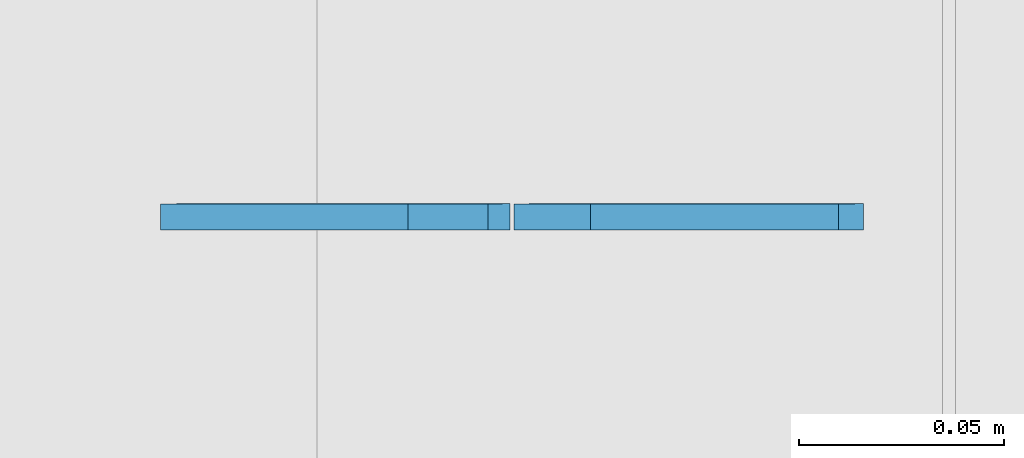
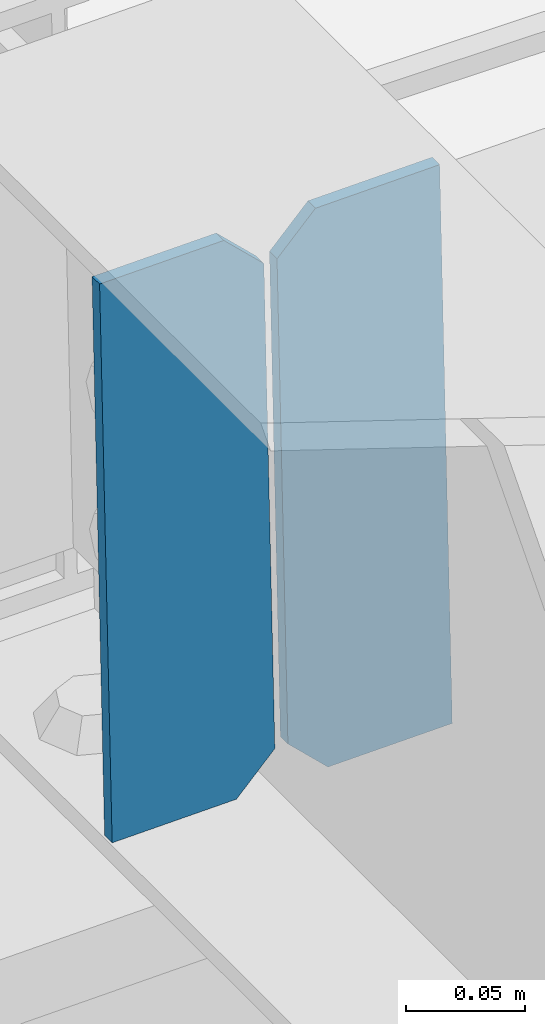
# One storey, part 3217 of 3843: 2 plates, 1 element without a shape of its own.
"""IFC2X3 building model written with IfcOpenShell, lengths in millimetres."""

import ifcopenshell
import ifcopenshell.guid

model = None  # the IFC model being written
_history = None  # IfcOwnerHistory: only IFC2X3 demands one
_inside = {}  # id of a spatial element -> (the spatial element, [elements in it])
_under = {}  # id of a project, library or spatial element -> (it, [spatial elements below it])
_declared = {}  # id of a project -> (the project, [libraries it declares])
_typed = {}  # id of a type object -> (the type object, [elements of that type])
_made_of = {}  # id of a material, layer set ... -> (it, [elements and type objects made of it])


def new_model(schema):
    """Start an empty IFC model of exactly this schema.

    Asked for "IFC4X3", IfcOpenShell would pick the latest addendum, in which some entities
    have other attributes; the version numbers below select the first issue.
    IFC2X3 requires an IfcOwnerHistory on every rooted entity: one is made here for all.
    """
    global model, _history
    if schema == "IFC4X3":
        model = ifcopenshell.file(schema_version=(4, 3, 0, 0))
    else:
        model = ifcopenshell.file(schema=schema)
    _inside.clear()
    _under.clear()
    _declared.clear()
    _typed.clear()
    _made_of.clear()
    _history = None
    if model.schema == "IFC2X3":
        org = make("IfcOrganization", Name="unknown")
        user = make(
            "IfcPersonAndOrganization",
            ThePerson=make("IfcPerson", FamilyName="unknown"),
            TheOrganization=org,
        )
        app = make(
            "IfcApplication",
            ApplicationDeveloper=org,
            Version="unknown",
            ApplicationFullName="unknown",
            ApplicationIdentifier="unknown",
        )
        _history = make(
            "IfcOwnerHistory",
            OwningUser=user,
            OwningApplication=app,
            ChangeAction="ADDED",
            CreationDate=0,
        )
    return model


def make(cls, **values):
    """One entity of the class cls with the attributes given. An attribute that is None is left unset."""
    return model.create_entity(
        cls, **{name: value for name, value in values.items() if value is not None}
    )


def rooted(cls, **values):
    """An entity with a GlobalId (a new one), such as an element, a storey or a relation."""
    return make(cls, GlobalId=ifcopenshell.guid.new(), OwnerHistory=_history, **values)


def si_unit(unit_type, name, prefix=None):
    """IfcSIUnit, for example si_unit("LENGTHUNIT", "METRE", prefix="MILLI")."""
    return make("IfcSIUnit", UnitType=unit_type, Prefix=prefix, Name=name)


def assignment(units):
    """IfcUnitAssignment: the units of a project."""
    return None if units is None else make("IfcUnitAssignment", Units=units)


def point(xyz):
    """IfcCartesianPoint."""
    return None if xyz is None else make("IfcCartesianPoint", Coordinates=xyz)


def direction(xyz):
    """IfcDirection."""
    return None if xyz is None else make("IfcDirection", DirectionRatios=xyz)


def frame(location, z_axis=None, x_axis=None):
    """IfcAxis2Placement3D, a coordinate frame: its origin and axes. An axis left out is left unset."""
    return make(
        "IfcAxis2Placement3D",
        Location=point(location),
        Axis=direction(z_axis),
        RefDirection=direction(x_axis),
    )


def origin_with_axes():
    """The frame at (0, 0, 0) with the z axis (0, 0, 1) and the x axis (1, 0, 0) written out."""
    return frame((0.0, 0.0, 0.0), z_axis=(0.0, 0.0, 1.0), x_axis=(1.0, 0.0, 0.0))


def place(relative_to, where):
    """IfcLocalPlacement: puts the frame where relative to a parent placement (None: the world)."""
    return make(
        "IfcLocalPlacement", PlacementRelTo=relative_to, RelativePlacement=where
    )


def context(
    kind, dimensions, precision=None, world=None, true_north=None, identifier=None
):
    """IfcGeometricRepresentationContext, for example the 3D "Model" context."""
    return make(
        "IfcGeometricRepresentationContext",
        ContextIdentifier=identifier,
        ContextType=kind,
        CoordinateSpaceDimension=dimensions,
        Precision=precision,
        WorldCoordinateSystem=world,
        TrueNorth=true_north,
    )


def subcontext(parent, identifier, kind, view, scale=None):
    """IfcGeometricRepresentationSubContext, for example "Body" below "Model"."""
    return make(
        "IfcGeometricRepresentationSubContext",
        ContextIdentifier=identifier,
        ContextType=kind,
        ParentContext=parent,
        TargetScale=scale,
        TargetView=view,
    )


def project(units=None, contexts=None):
    """IfcProject with its units and contexts."""
    return rooted(
        "IfcProject",
        Name="project",
        RepresentationContexts=contexts,
        UnitsInContext=assignment(units),
    )


def spatial(cls, under=None, at=None, **own):
    """A site, building, storey or space (cls), placed at a placement, below another one or the project."""
    s = rooted(cls, ObjectPlacement=at, **own)
    if under is not None:
        _under.setdefault(under.id(), (under, []))[1].append(s)
    return s


def faces_of(points, faces, orient=None, outer=None):
    """IfcFace entities. A face is a list of loops; a loop is a list of indices into points, from 0.

    orient and outer hold one flag for each loop. By default every Orientation is true, the
    first loop of a face is its IfcFaceOuterBound and the others are IfcFaceBound.
    """
    made = []
    for i, loops in enumerate(faces):
        bounds = []
        for j, loop in enumerate(loops):
            is_outer = j == 0 if outer is None else outer[i][j]
            bounds.append(
                make(
                    "IfcFaceOuterBound" if is_outer else "IfcFaceBound",
                    Bound=make("IfcPolyLoop", Polygon=[points[k] for k in loop]),
                    Orientation=True if orient is None else orient[i][j],
                )
            )
        made.append(make("IfcFace", Bounds=bounds))
    return made


def faceted_brep(points, faces, orient=None, outer=None, voids=None):
    """IfcFacetedBrep: a solid bounded by flat faces; with voids (closed shells), ...WithVoids."""
    shared = [point(p) for p in points]
    hull = make("IfcClosedShell", CfsFaces=faces_of(shared, faces, orient, outer))
    if voids is None:
        return make("IfcFacetedBrep", Outer=hull)
    return make(
        "IfcFacetedBrepWithVoids",
        Outer=hull,
        Voids=[
            make(cls, CfsFaces=faces_of(shared, fs, o, b)) for cls, fs, o, b in voids
        ],
    )


def shape(context_of_items, identifier, shape_type, items):
    """IfcShapeRepresentation: the items that make up one representation, for example the "Body"."""
    return make(
        "IfcShapeRepresentation",
        ContextOfItems=context_of_items,
        RepresentationIdentifier=identifier,
        RepresentationType=shape_type,
        Items=items,
    )


def material(Name=None, Category=None):
    """IfcMaterial."""
    return make("IfcMaterial", Name=Name, Category=Category)


def made_of(thing, what):
    """Note that an element or type object is made of a material, layer set ...; save() writes the relation."""
    if what is not None:
        _made_of.setdefault(what.id(), (what, []))[1].append(thing)
    return thing


def type_object(cls, material=None, **own):
    """A type object (cls), such as IfcWallType, which elements share."""
    return made_of(rooted(cls, **own), material)


def element(
    cls,
    number,
    at=None,
    inside=None,
    cuts=None,
    type_object=None,
    material=None,
    context=None,
    identifier="Body",
    shape_type=None,
    held_by="IfcProductDefinitionShape",
    body=None,
    shapes=None,
    **own,
):
    """One element of the class cls, such as IfcWall. Its Tag is "e" and its number.

    at: its placement. inside: the storey or other place that contains it. cuts: it is an
    opening in that element (IfcRelVoidsElement). A single representation is given by context,
    identifier, shape_type and body (its items); several are given by shapes. held_by: the class
    of the entity that holds the representations. save() writes the other relations.
    """
    e = rooted(cls, Tag="e%d" % number, ObjectPlacement=at, **own)
    if body is not None:
        shapes = [shape(context, identifier, shape_type, body)]
    if shapes is not None:
        e.Representation = make(held_by, Representations=shapes)
    if inside is not None:
        _inside.setdefault(inside.id(), (inside, []))[1].append(e)
    if cuts is not None:
        rooted(
            "IfcRelVoidsElement", RelatingBuildingElement=cuts, RelatedOpeningElement=e
        )
    if type_object is not None:
        _typed.setdefault(type_object.id(), (type_object, []))[1].append(e)
    return made_of(e, material)


def aggregate(whole, parts):
    """IfcRelAggregates: a whole, such as a stair, and the parts it consists of."""
    return rooted("IfcRelAggregates", RelatingObject=whole, RelatedObjects=parts)


def save(model, path):
    """Write the relations noted so far, then the file.

    IfcRelAggregates (storeys below a building ...), IfcRelContainedInSpatialStructure (elements
    in a storey), IfcRelDefinesByType, IfcRelAssociatesMaterial and IfcRelDeclares: one each for
    every whole, place, type object, material and project.
    """
    for whole, parts in _under.values():
        aggregate(whole, parts)
    for where, things in _inside.values():
        rooted(
            "IfcRelContainedInSpatialStructure",
            RelatedElements=things,
            RelatingStructure=where,
        )
    for kind, things in _typed.values():
        rooted("IfcRelDefinesByType", RelatedObjects=things, RelatingType=kind)
    for what, things in _made_of.values():
        rooted("IfcRelAssociatesMaterial", RelatedObjects=things, RelatingMaterial=what)
    for by, libraries in _declared.values():
        rooted("IfcRelDeclares", RelatingContext=by, RelatedDefinitions=libraries)
    model.write(path)


model = new_model("IFC2X3")

# Units and contexts
model_context = context("Model", 3, precision=1e-05, world=origin_with_axes())
body_context = subcontext(model_context, "Body", "Model", "MODEL_VIEW")
ifc_project = project(units=[si_unit("LENGTHUNIT", "METRE", prefix="MILLI"), si_unit("AREAUNIT", "SQUARE_METRE"), si_unit("VOLUMEUNIT", "CUBIC_METRE"), si_unit("MASSUNIT", "GRAM", prefix="KILO"), si_unit("TIMEUNIT", "SECOND"), si_unit("PLANEANGLEUNIT", "RADIAN"), si_unit("SOLIDANGLEUNIT", "STERADIAN"), si_unit("THERMODYNAMICTEMPERATUREUNIT", "DEGREE_CELSIUS"), si_unit("LUMINOUSINTENSITYUNIT", "LUMEN")], contexts=[model_context])

# Site, building, storey
site_placement = place(None, origin_with_axes())
site = spatial("IfcSite", under=ifc_project, at=site_placement, CompositionType="ELEMENT")
building_placement = place(site_placement, origin_with_axes())
building = spatial("IfcBuilding", under=site, at=building_placement, Name="Undefined", CompositionType="ELEMENT")
storey_placement = place(building_placement, origin_with_axes())
storey = spatial("IfcBuildingStorey", under=building, at=storey_placement, Name="Undefined", CompositionType="ELEMENT", Elevation=0.0)

# Assembly, plates
assembly_placement = place(storey_placement, origin_with_axes())
assembly = element("IfcElementAssembly", 1, at=assembly_placement, inside=storey, Name="BEAM", AssemblyPlace="NOTDEFINED", PredefinedType="RIGID_FRAME")
ifc_material = material(Name="STEEL/A572-50")
plate_type = type_object("IfcPlateType", PredefinedType="NOTDEFINED")
plate_1_placement = place(assembly_placement, frame((38029.896478264, 33683.5973282811, 45460.899481431), z_axis=(-0.0211520980666537, -7.48509999611997e-05, 0.999776266544024), x_axis=(-0.999776269345987, 1.58400000145775e-06, -0.021152098007311)))
plate_1 = element("IfcPlate", 2, at=plate_1_placement, type_object=plate_type, material=ifc_material, Name="PLATE", context=body_context, shape_type="Brep", body=[
    faceted_brep([(0.0, -3.17499999999927, 0.0), (6.83940015733242e-10, -3.17499999996653, 288.924999998613), (6.54836185276508e-10, 3.17500000001746, 288.924999998591), (0.0, 3.17499999999927, 0.0), (60.3250007643655, -3.17500000017753, 288.924999998606), (60.3250007643219, 3.17499999979918, 288.924999998584), (79.3750000013097, -3.17500000025029, 269.875000761494), (79.375000001266, 3.17499999972642, 269.875000761487), (79.375000000713, -3.17500000026484, 19.0499992370605), (79.3750000006985, 3.17499999971187, 19.0499992370533), (60.325000763667, -3.17500000020664, -1.45519152283669e-11), (60.3250007636234, 3.17499999977736, -3.63797880709171e-11)], [[[0, 1, 2, 3]], [[1, 4, 5, 2]], [[4, 6, 7, 5]], [[6, 8, 9, 7]], [[8, 10, 11, 9]], [[10, 0, 3, 11]], [[5, 7, 9, 11, 3, 2]], [[10, 8, 6, 4, 1, 0]]]),
])
plate_2_placement = place(assembly_placement, frame((37944.1906575744, 33683.5974640368, 45459.086217836), z_axis=(-0.0211520980666537, -7.48509999611997e-05, 0.999776266544024), x_axis=(-0.999776269345987, 1.58400000145775e-06, -0.021152098007311)))
plate_2 = element("IfcPlate", 3, at=plate_2_placement, type_object=plate_type, material=ifc_material, Name="PLATE", context=body_context, shape_type="Brep", body=[
    faceted_brep([(4.36557456851006e-11, -3.17499999998836, 19.0499992370969), (6.11180439591408e-10, -3.17499999996653, 269.875000761516), (5.96628524363041e-10, 3.17500000001746, 269.875000761502), (1.45519152283669e-11, 3.17499999998836, 19.0499992370824), (19.0499992376572, -3.17500000003201, 288.924999998606), (19.0499992376281, 3.1749999999447, 288.924999998584), (79.3750000013242, -3.17500000025029, 288.924999998591), (79.3750000013097, 3.1749999997337, 288.92499999857), (79.3750000006548, -3.17500000026484, -2.18278728425503e-11), (79.3750000006403, 3.17499999969732, -2.91038304567337e-11), (19.0499992370023, -3.17500000005384, 0.0), (19.0499992369587, 3.17499999992287, -1.45519152283669e-11)], [[[0, 1, 2, 3]], [[1, 4, 5, 2]], [[4, 6, 7, 5]], [[6, 8, 9, 7]], [[8, 10, 11, 9]], [[10, 0, 3, 11]], [[5, 7, 9, 11, 3, 2]], [[10, 8, 6, 4, 1, 0]]]),
])
aggregate(assembly, [plate_1, plate_2])

save(model, "model.ifc")
